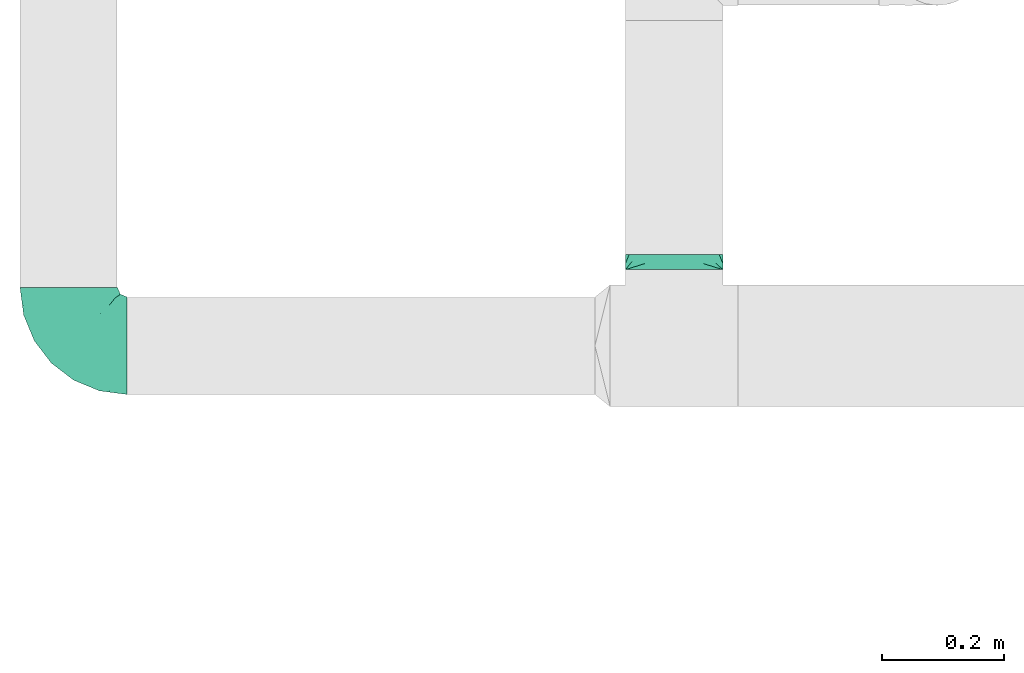
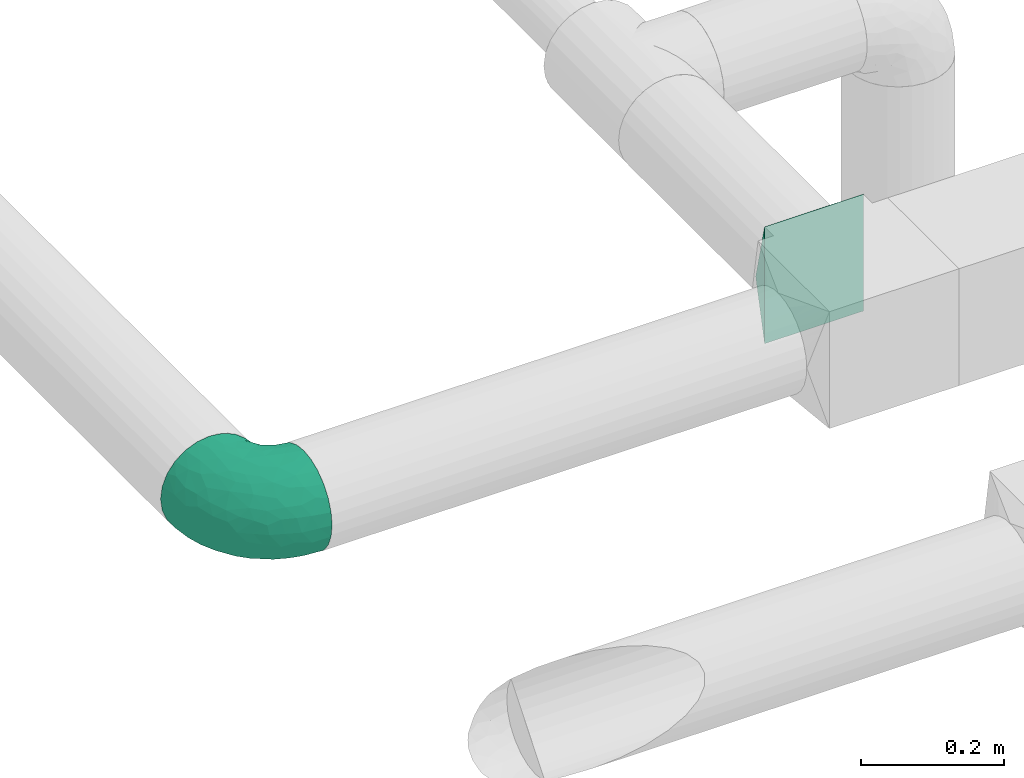
# One storey, part 7 of 12: 2 flow fittings.
"""IFC2X3 building model written with IfcOpenShell, lengths in millimetres."""

from ifc_helpers import new_model, entity, si_unit, converted_unit, derived_unit, direction, frame, origin, place, context, subcontext, project, spatial, faceted_brep, source, transform, mapped, material, type_object, type_shapes, element, save


model = new_model("IFC2X3")

# Units and contexts
model_context = context("Model", 3, precision=0.01, world=origin(), true_north=direction((6.12303176911189e-17, 1.0)))
body_context = subcontext(model_context, "Body", "Model", "MODEL_VIEW")
ifc_project = project(units=[si_unit("LENGTHUNIT", "METRE", prefix="MILLI"), si_unit("AREAUNIT", "SQUARE_METRE"), si_unit("VOLUMEUNIT", "CUBIC_METRE"), converted_unit("PLANEANGLEUNIT", "DEGREE", entity("IfcRatioMeasure", 0.0174532925199433), si_unit("PLANEANGLEUNIT", "RADIAN"), dimensions=[0, 0, 0, 0, 0, 0, 0]), si_unit("MASSUNIT", "GRAM", prefix="KILO"), derived_unit("MASSDENSITYUNIT", [(si_unit("MASSUNIT", "GRAM", prefix="KILO"), 1), (si_unit("LENGTHUNIT", "METRE"), -3)]), si_unit("TIMEUNIT", "SECOND"), si_unit("FREQUENCYUNIT", "HERTZ"), si_unit("THERMODYNAMICTEMPERATUREUNIT", "DEGREE_CELSIUS"), derived_unit("THERMALTRANSMITTANCEUNIT", [(si_unit("MASSUNIT", "GRAM", prefix="KILO"), 1), (si_unit("THERMODYNAMICTEMPERATUREUNIT", "KELVIN"), -1), (si_unit("TIMEUNIT", "SECOND"), -3)]), derived_unit("VOLUMETRICFLOWRATEUNIT", [(si_unit("LENGTHUNIT", "METRE"), 3), (si_unit("TIMEUNIT", "SECOND"), -1)]), si_unit("ELECTRICCURRENTUNIT", "AMPERE"), si_unit("ELECTRICVOLTAGEUNIT", "VOLT"), si_unit("POWERUNIT", "WATT"), si_unit("FORCEUNIT", "NEWTON", prefix="KILO"), si_unit("ILLUMINANCEUNIT", "LUX"), si_unit("LUMINOUSFLUXUNIT", "LUMEN"), si_unit("LUMINOUSINTENSITYUNIT", "CANDELA"), derived_unit("USERDEFINED", [(si_unit("MASSUNIT", "GRAM", prefix="KILO"), -1), (si_unit("LENGTHUNIT", "METRE"), -2), (si_unit("TIMEUNIT", "SECOND"), 3), (si_unit("LUMINOUSFLUXUNIT", "LUMEN"), 1)]), derived_unit("LINEARVELOCITYUNIT", [(si_unit("LENGTHUNIT", "METRE"), 1), (si_unit("TIMEUNIT", "SECOND"), -1)]), si_unit("PRESSUREUNIT", "PASCAL"), derived_unit("USERDEFINED", [(si_unit("LENGTHUNIT", "METRE"), -2), (si_unit("MASSUNIT", "GRAM", prefix="KILO"), 1), (si_unit("TIMEUNIT", "SECOND"), -2)])], contexts=[model_context])

# Site, building, storey
site_placement = place(None, origin())
site = spatial("IfcSite", under=ifc_project, at=site_placement, CompositionType="ELEMENT")
building_placement = place(site_placement, origin())
building = spatial("IfcBuilding", under=site, at=building_placement, CompositionType="ELEMENT")
storey_placement = place(building_placement, frame((0.0, 0.0, 4000.0)))
storey = spatial("IfcBuildingStorey", under=building, at=storey_placement, Name="01 Level", CompositionType="ELEMENT", Elevation=4000.0)

# Flow fittings
duct_fitting_type_1 = type_object("IfcDuctFittingType", Name="Air_Elbow short_Circ", PredefinedType="NOTDEFINED")
shared_shape_1 = source(origin(), body_context, "Body", "Brep", [
    faceted_brep([(-96.0, 0.0, -80.0), (-96.0, -20.7055236082018, -77.2740661031254), (-96.0, -40.0, -69.2820323027551), (-96.0, -56.5685424949239, -56.5685424949238), (-96.0, -69.2820323027551, -40.0), (-96.0, -77.2740661031255, -20.7055236082016), (-96.0, -80.0, 0.0), (-96.0, -77.2740661031253, 20.7055236082021), (-96.0, -69.2820323027549, 40.0), (-96.0, -56.5685424949235, 56.5685424949241), (-96.0, -40.0, 69.2820323027553), (-96.0, -30.3527618041005, 73.2780492029404), (-96.0, -20.7055236082013, 77.2740661031256), (-96.0, 0.0, 80.0), (-96.0, 20.705523608202, 77.2740661031254), (-96.0, 40.0, 69.2820323027549), (-96.0, 56.568542494924, 56.5685424949236), (-96.0, 69.2820323027553, 40.0), (-96.0, 77.2740661031256, 20.7055236082014), (-96.0, 80.0, 0.0), (-96.0, 77.2740661031254, -20.7055236082019), (-96.0, 69.282032302755, -40.0), (-96.0, 56.5685424949237, -56.5685424949239), (-96.0, 40.0, -69.2820323027552), (-96.0, 20.7055236082015, -77.2740661031255), (0.0, -96.0, -80.0), (20.7055236082025, -96.0, -77.2740661031255), (40.0, -96.0, -69.2820323027552), (56.5685424949246, -96.0, -56.5685424949239), (69.2820323027559, -96.0, -40.0), (77.2740661031264, -96.0, -20.7055236082019), (80.0, -96.0, 0.0), (77.2740661031265, -96.0, 20.7055236082014), (69.2820323027562, -96.0, 40.0), (56.5685424949249, -96.0, 56.5685424949236), (40.0, -96.0, 69.2820323027549), (20.7055236082029, -96.0, 77.2740661031254), (0.0, -96.0, 80.0), (-20.7055236082004, -96.0, 77.2740661031256), (-40.0, -96.0, 69.2820323027553), (-56.5685424949226, -96.0, 56.5685424949241), (-69.2820323027539, -96.0, 40.0), (-77.2740661031244, -96.0, 20.7055236082021), (-80.0, -96.0, 0.0), (-77.2740661031245, -96.0, -20.7055236082016), (-69.2820323027542, -96.0, -40.0), (-56.5685424949229, -96.0, -56.5685424949238), (-40.0, -96.0, -69.2820323027551), (-30.3527618041, -96.0, -73.2780492029402), (-20.7055236082008, -96.0, -77.2740661031254), (-69.6571465232348, -6.28172173912476, 79.9611058756859), (-66.7862289407348, 74.1387210661139, 22.9795507758541), (-78.4902527850466, 65.2482264041437, 44.9229732355936), (-55.1380888291464, 64.4450584799279, 39.5029426177976), (-75.1250134759213, -46.3506195730757, 68.0011973810265), (-79.9123689128389, -22.4151301859584, 77.2816866630488), (-67.1316735243184, 51.7530432423058, 58.5204707533666), (-62.9760666105318, 34.5362195419601, 70.0448030595901), (-46.2820694578435, 43.7397705581167, 60.5188244193914), (-76.2276812833835, 77.3969248578635, 0.0), (-50.4478480619551, 74.0029454268759, 0.0), (-6.30632028234235, -70.6421404093778, 79.9513108199466), (-27.189372084162, -68.980536479128, 76.8941402015288), (-29.8609237116382, 28.9682345099716, 65.8760199345924), (-47.7584488981354, 13.6212410427434, 76.3881123659885), (43.7397637815864, -46.2820598522933, 60.518827155348), (51.7530435574228, -67.1316742002235, 58.5204705859065), (57.6005967886466, -33.4719572927763, 39.0176496769077), (-74.2591571701267, 14.3645886695287, 78.2829835259588), (7.8513563843086, 42.4938374080907, 21.3232874317503), (23.3846344985257, 27.9066135199674, 24.7887114209846), (28.4507934888335, 28.4507934888321, 0.0), (-84.190871651952, -70.905997349447, 41.7100461919055), (10.21505333872, 32.0754161621096, 38.020212353501), (-0.0180155578363953, 25.9284255475521, 53.836744023285), (24.7272484782103, 2.06889411058577, 53.4325037134459), (-41.7574890626937, -15.123136403511, 79.988056483004), (-64.5619855594544, -27.52018553659, 77.2892967298799), (-8.0, 56.420471066061, 0.0), (-29.2239240309769, 65.2117082464685, 0.0), (-24.5336756868846, 60.9669573051438, 23.5003835585885), (-16.4008295437786, -51.3122057461681, 79.8609584412684), (-84.6862915010143, -84.6862915010152, 0.0), (-83.0529092063249, -83.0529092103045, 19.0855009657076), (-82.4185651555764, -62.2587017800419, 53.3339952483838), (-46.3022193149449, -75.902750025661, 67.8445262622594), (-9.5260688639158, 47.7232209131232, 35.4187162694583), (74.1387213421635, -66.7862279048973, 22.9795492840646), (34.536215572589, -62.976064096567, 70.0448048426748), (14.3645870599314, -74.259154996167, 78.2829837700474), (65.2482273833467, -78.4902510979302, 44.9229715327465), (-25.6317751341749, -1.2640655514879, 76.9124052095498), (-12.3935655196116, -25.4017250572252, 78.8652642576962), (60.9669574479924, -24.5336725945725, 23.5003789659965), (64.4450597015273, -55.1380839274934, 39.5029384026545), (69.8186739706361, -42.5625104806759, 16.7980672722629), (77.3969247188647, -76.2276802275763, 0.0), (74.002945426877, -50.4478480619565, 0.0), (-52.4774893100348, -53.0631556360015, 72.0041598972686), (-66.5995156060253, -66.5995146556305, 58.6370817132137), (-76.4857465466113, -78.9385356944492, 38.5867538667356), (-62.2587016209511, -82.4185645906685, 53.3339956492136), (13.6212369177471, -47.7584433090926, 76.3881128402526), (28.9682276847195, -29.8609133580269, 65.8760207540895), (-6.49930484510329, 53.7890406240985, 15.4645725223014), (-33.731289034344, -40.0214486160993, 79.0537019298314), (46.1336936566893, -26.2441492635858, 50.151541479116), (50.0005984633279, -1.26038287501495, 17.5763945268078), (56.4204710660622, -8.0, 0.0), (42.4356322774479, 10.225396744416, 0.0), (-45.4536887619888, 68.8356359385787, 23.6914879663761), (-33.3493864711472, 57.4572215948989, 39.1720709545353), (35.9683398342664, 11.0724559744972, 30.5391080332169), (-26.2441652621668, 46.1336984778153, 50.1515448602929), (36.6749123583047, 17.5982116941791, 14.5644188861001), (65.2117082464696, -29.2239240309784, 0.0), (49.5968730216335, -12.1440064858134, 34.8325942562253), (-47.1533280807863, -29.0746114834461, 78.9127210009486), (-0.981722938535007, -51.3162880079176, 79.4920802366619), (-1.95170750213435, -1.95169859379814, 70.9272590604952), (12.4951682569875, -20.0804783439543, 71.2292489374933), (13.0725391330592, -1.13338064801589, 63.5790506070627), (-1.93327092594732, 13.4823821925323, 63.7412032706882), (-18.9298205951927, 13.0048872663631, 70.6672094580024), (10.2253967444173, 42.4356322774466, 0.0), (-68.9805369123341, -27.1893702897943, -76.8941406355589), (-46.3506180288022, -75.1250185023919, -68.0011970559212), (-27.5201921618733, -64.5619784506715, -77.2892959136582), (-22.4151342180024, -79.9123577737124, -77.2816862456941), (-74.2591561090454, 14.364589592643, -78.2829832920378), (-66.78622820047, 74.1387209331735, -22.9795507950237), (-42.5625109127564, 69.8186736490614, -16.7980693145318), (-70.6421421271429, -6.30631801763141, -79.9513108797024), (-1.2640784754681, -25.6317655571971, -76.9124065444174), (-15.1231475192353, -41.7574898106582, -79.9880566497423), (-25.401718902627, -12.3935649209934, -78.8652635038296), (-82.4185656924104, -62.258701559575, -53.3339952529289), (-66.5995166501766, -66.5995137008527, -58.6370816545605), (-78.9385361639639, -76.4857467527193, -38.5867530236755), (53.7890400497189, -6.49930371043273, -15.4645720709197), (60.9669567069012, -24.5336743104721, -23.5003834743896), (-24.5336751436549, 60.9669572920351, -23.5003828649414), (-55.1380878256228, 64.4450583029017, -39.5029424837467), (-46.2820677406335, 43.7397707662098, -60.5188237522514), (-26.2441631797834, 46.1336980827234, -50.1515441608816), (-29.8609212227281, 28.9682353164184, -65.8760186412515), (74.1387206827049, -66.7862275406284, -22.9795512458422), (-40.0214489824224, -33.7312845774564, -79.0537024061946), (-78.4902524468744, 65.2482264004152, -44.9229731872606), (-75.902751427461, -46.3022186029078, -67.8445263463497), (-70.9059970555813, -84.1908706304995, -41.7100473389448), (-62.9760652707231, 34.536220162299, -70.044802546446), (-67.1316724627346, 51.7530434014037, -58.5204704180807), (-33.4719630839568, 57.6005950429912, -39.0176564793206), (-51.3122062597491, -16.4008248291117, -79.8609586691244), (-6.28171714934502, -69.65712797409, -79.9611061760713), (51.7530427306645, -67.1316703492073, -58.5204706539109), (-83.0529092397056, -83.0529091932979, -19.0855009185769), (68.8356349913375, -45.45368838847, -23.6914905340598), (-62.258701383479, -82.4185638376438, -53.3339962098694), (34.53621889603, -62.9760621802168, -70.0448028055675), (-1.26038544288408, 50.0005998980998, -17.5763953891677), (14.3645887716112, -74.2591526334116, -78.2829833202131), (13.6212385978137, -47.75844096294, -76.3881120677864), (65.2482261461557, -78.4902526871683, -44.9229735979605), (32.0754071702863, 10.2150656939878, -38.0202105656364), (25.9284207554091, -0.0180077987247146, -53.8367428868672), (2.068884460932, 24.7272580800759, -53.4325021883878), (47.723215348146, -9.52606271707191, -35.4187195087105), (42.4938359077841, 7.8513587520169, -21.3232866357369), (27.9066094773716, 23.3846413342612, -24.7887058003424), (28.9682309044935, -29.8609168472814, -65.8760199178674), (64.4450577206072, -55.1380878066959, -39.5029434692504), (-53.063150048133, -52.4774843719861, -72.0041634993662), (43.7397687897612, -46.2820667462245, -60.5188250739327), (-47.7584463040963, 13.6212426330217, -76.3881115880261), (57.4572201066452, -33.3493827160302, -39.1720708806551), (11.0724494499294, 35.9683446288498, -30.5391089716619), (46.1336964749623, -26.2441642243134, -50.1515465265606), (17.5982028158329, 36.6749194460897, -14.5644209948051), (-12.1440097531109, 49.5968729214507, -34.8325978072281), (-29.0746218055845, -47.1533256390974, -78.912719851915), (-51.3162911259858, -0.981717610547608, -79.4920798409907), (-1.95170139871169, -1.95169735730944, -70.9272563527003), (-20.0804667507281, 12.4951842966219, -71.2292388196267), (-1.13337124471279, 13.072540998247, -63.5790448193562), (13.4823844636247, -1.93327501577089, -63.7412039856557), (13.0048800657406, -18.9298191902065, -70.6672121474654)], [[[0, 1, 2, 3, 4, 5, 6, 7, 8, 9, 10, 11, 12, 13, 14, 15, 16, 17, 18, 19, 20, 21, 22, 23, 24]], [[25, 26, 27, 28, 29, 30, 31, 32, 33, 34, 35, 36, 37, 38, 39, 40, 41, 42, 43, 44, 45, 46, 47, 48, 49]], [[50, 13, 12]], [[51, 52, 53]], [[10, 54, 55]], [[56, 57, 58]], [[59, 51, 60]], [[61, 62, 38]], [[63, 57, 64]], [[65, 66, 67]], [[17, 16, 52]], [[15, 57, 56]], [[14, 13, 68]], [[69, 70, 71]], [[8, 7, 72]], [[68, 64, 57]], [[73, 74, 75]], [[76, 50, 77]], [[57, 15, 14]], [[9, 54, 10]], [[55, 12, 11, 10]], [[78, 79, 80]], [[62, 61, 81]], [[82, 83, 6]], [[63, 58, 57]], [[83, 7, 6]], [[8, 72, 84]], [[56, 16, 15]], [[84, 9, 8]], [[62, 85, 39]], [[86, 74, 73]], [[59, 18, 51]], [[18, 17, 51]], [[32, 87, 33]], [[35, 34, 66]], [[36, 88, 89]], [[90, 34, 33]], [[88, 36, 35]], [[91, 76, 92]], [[90, 33, 87]], [[93, 94, 95]], [[35, 66, 88]], [[32, 96, 87]], [[85, 40, 39]], [[87, 97, 95]], [[98, 99, 85]], [[41, 100, 42]], [[42, 100, 83]], [[101, 99, 100]], [[102, 88, 103]], [[43, 83, 82]], [[104, 78, 80]], [[38, 62, 39]], [[98, 85, 62]], [[92, 76, 105]], [[65, 106, 103]], [[101, 41, 40]], [[37, 61, 38]], [[107, 108, 109]], [[51, 53, 110]], [[37, 36, 89]], [[79, 110, 80]], [[110, 79, 60]], [[111, 110, 53]], [[112, 70, 73]], [[113, 86, 111]], [[71, 114, 109]], [[75, 103, 106]], [[93, 95, 115]], [[37, 89, 61]], [[108, 93, 115]], [[67, 93, 116]], [[107, 116, 93]], [[13, 50, 68]], [[117, 76, 77]], [[98, 117, 77]], [[99, 54, 84]], [[40, 85, 101]], [[98, 54, 99]], [[105, 62, 81]], [[89, 118, 61]], [[88, 66, 65]], [[94, 66, 90]], [[16, 56, 52]], [[111, 53, 56]], [[76, 64, 50]], [[64, 76, 91]], [[119, 92, 120]], [[61, 118, 81]], [[120, 121, 119]], [[116, 112, 75]], [[121, 122, 119]], [[119, 122, 123]], [[113, 63, 74]], [[119, 123, 91]], [[86, 113, 74]], [[122, 121, 75]], [[54, 98, 77]], [[105, 98, 62]], [[59, 19, 18]], [[97, 87, 96]], [[32, 31, 96]], [[102, 89, 88]], [[14, 68, 57]], [[64, 68, 50]], [[41, 101, 100]], [[99, 101, 85]], [[9, 84, 54]], [[100, 99, 72]], [[81, 92, 105]], [[102, 92, 118]], [[81, 118, 92]], [[102, 118, 89]], [[84, 72, 99]], [[83, 100, 72]], [[72, 7, 83]], [[42, 83, 43]], [[17, 52, 51]], [[53, 52, 56]], [[34, 90, 66]], [[94, 90, 87]], [[55, 54, 77]], [[55, 50, 12]], [[55, 77, 50]], [[60, 51, 110]], [[80, 110, 111]], [[86, 104, 80]], [[58, 113, 111]], [[111, 86, 80]], [[73, 69, 86]], [[69, 73, 70]], [[112, 73, 75]], [[69, 124, 104]], [[108, 107, 93]], [[112, 114, 70]], [[93, 67, 94]], [[112, 107, 114]], [[70, 114, 71]], [[109, 114, 107]], [[106, 116, 75]], [[116, 107, 112]], [[94, 67, 66]], [[67, 116, 106]], [[115, 95, 97]], [[69, 104, 86]], [[78, 104, 124]], [[69, 71, 124]], [[87, 95, 94]], [[88, 65, 103]], [[106, 65, 67]], [[56, 58, 111]], [[113, 58, 63]], [[117, 105, 76]], [[105, 117, 98]], [[63, 64, 123]], [[119, 91, 92]], [[91, 123, 64]], [[74, 63, 122]], [[123, 122, 63]], [[74, 122, 75]], [[121, 103, 75]], [[103, 121, 120]], [[120, 102, 103]], [[102, 120, 92]], [[1, 125, 2]], [[126, 127, 128]], [[129, 0, 24]], [[130, 60, 131]], [[0, 132, 1]], [[133, 134, 135]], [[136, 137, 138]], [[139, 108, 140]], [[3, 136, 4]], [[141, 142, 131]], [[138, 5, 4]], [[143, 144, 145]], [[30, 29, 146]], [[135, 134, 147]], [[148, 21, 130]], [[149, 3, 2]], [[20, 59, 130]], [[45, 44, 150]], [[151, 23, 152]], [[143, 152, 153]], [[152, 23, 22]], [[151, 24, 23]], [[125, 132, 154]], [[21, 148, 22]], [[155, 25, 49]], [[151, 129, 24]], [[20, 130, 21]], [[156, 28, 27]], [[157, 82, 6]], [[115, 158, 140]], [[157, 44, 43]], [[5, 138, 157]], [[150, 159, 45]], [[160, 27, 26]], [[161, 78, 124]], [[45, 159, 46]], [[128, 49, 48, 47]], [[2, 125, 149]], [[134, 155, 127]], [[162, 163, 160]], [[29, 28, 164]], [[126, 47, 46]], [[165, 166, 167]], [[25, 162, 26]], [[166, 165, 168]], [[132, 125, 1]], [[108, 115, 140]], [[169, 170, 71]], [[171, 160, 163]], [[27, 160, 156]], [[146, 164, 172]], [[173, 137, 149]], [[97, 96, 146]], [[171, 174, 160]], [[175, 151, 145]], [[160, 174, 156]], [[173, 149, 125]], [[47, 126, 128]], [[158, 115, 97]], [[6, 5, 157]], [[146, 172, 158]], [[96, 30, 146]], [[176, 158, 172]], [[177, 170, 165]], [[178, 168, 176]], [[71, 179, 124]], [[167, 145, 144]], [[141, 131, 79]], [[96, 31, 30]], [[78, 141, 79]], [[153, 141, 180]], [[161, 180, 141]], [[25, 155, 162]], [[147, 134, 181]], [[173, 181, 127]], [[137, 126, 159]], [[3, 149, 136]], [[173, 126, 137]], [[147, 125, 154]], [[129, 182, 132]], [[151, 152, 143]], [[142, 152, 148]], [[28, 156, 164]], [[176, 172, 156]], [[134, 163, 155]], [[163, 134, 133]], [[183, 135, 184]], [[132, 182, 154]], [[184, 185, 183]], [[180, 177, 167]], [[185, 186, 183]], [[183, 186, 187]], [[178, 171, 166]], [[183, 187, 133]], [[168, 178, 166]], [[186, 185, 167]], [[126, 173, 127]], [[147, 173, 125]], [[60, 130, 59]], [[20, 19, 59]], [[0, 129, 132]], [[175, 129, 151]], [[26, 162, 160]], [[163, 162, 155]], [[4, 136, 138]], [[137, 136, 149]], [[46, 159, 126]], [[138, 137, 150]], [[154, 135, 147]], [[175, 135, 182]], [[154, 182, 135]], [[175, 182, 129]], [[159, 150, 137]], [[157, 138, 150]], [[82, 157, 43]], [[150, 44, 157]], [[29, 164, 146]], [[172, 164, 156]], [[22, 148, 152]], [[142, 148, 130]], [[155, 128, 127]], [[128, 155, 49]], [[97, 146, 158]], [[140, 158, 176]], [[168, 139, 140]], [[174, 178, 176]], [[176, 168, 140]], [[165, 169, 168]], [[169, 165, 170]], [[177, 165, 167]], [[169, 109, 139]], [[78, 161, 141]], [[177, 179, 170]], [[141, 153, 142]], [[177, 161, 179]], [[170, 179, 71]], [[124, 179, 161]], [[144, 180, 167]], [[180, 161, 177]], [[142, 153, 152]], [[153, 180, 144]], [[79, 131, 60]], [[169, 139, 168]], [[108, 139, 109]], [[169, 71, 109]], [[130, 131, 142]], [[151, 143, 145]], [[144, 143, 153]], [[156, 174, 176]], [[178, 174, 171]], [[147, 181, 173]], [[181, 134, 127]], [[171, 163, 187]], [[183, 133, 135]], [[133, 187, 163]], [[166, 171, 186]], [[187, 186, 171]], [[166, 186, 167]], [[185, 145, 167]], [[145, 185, 184]], [[184, 175, 145]], [[175, 184, 135]]]),
])
type_shapes(duct_fitting_type_1, [shared_shape_1])
flow_fitting_1_placement = place(storey_placement, frame((22191.748982204, -68506.4439409626, 3000.0), z_axis=(0.0, 0.0, 1.0), x_axis=(-1.0, 0.0, 0.0)))
element("IfcFlowFitting", 1, at=flow_fitting_1_placement, inside=storey, type_object=duct_fitting_type_1, Name="elbow_short_001:Air_Elbow short_Circ", ObjectType="elbow_short_001:Air_Elbow short_Circ", context=body_context, shape_type="MappedRepresentation", body=[
    mapped(shared_shape_1, transform((0.0, 0.0, 0.0), scale=1.0)),
])
ifc_material = material(Name="Material_Duct")
duct_fitting_type_2 = type_object("IfcDuctFittingType", Name="Air_Multi shape transition_Circ", PredefinedType="NOTDEFINED", material=ifc_material)
shared_shape_2 = source(origin(), body_context, "Body", "Brep", [
    faceted_brep([(25.0, 0.0, -80.0), (25.0, 7.55917892584856, -78.4963858244121), (25.0, 15.1183578516973, -76.9927716488251), (25.0, 22.8665162204521, -75.4515671248636), (25.0, 26.7405954048296, -74.6809648628828), (25.0, 30.614674589207, -73.9103626009021), (25.0, 37.1031415656362, -69.5749075744073), (25.0, 43.5916085420653, -65.2394525479126), (25.0, 50.0800755184945, -60.9039975214178), (25.0, 56.5685424949236, -56.5685424949231), (25.0, 60.9039975214184, -50.0800755184939), (25.0, 65.2394525479132, -43.5916085420648), (25.0, 69.574907574408, -37.1031415656356), (25.0, 73.9103626009028, -30.6146745892065), (25.0, 75.4515671268645, -22.8665162103963), (25.0, 76.9927716528262, -15.1183578315862), (25.0, 77.7445787396197, -11.3387683736895), (25.0, 78.4963858264131, -7.55917891579276), (25.0, 80.0, 0.0), (25.0, 78.496385824413, 7.55917892584876), (25.0, 76.992771648826, 15.1183578516975), (25.0, 75.4515671248645, 22.8665162204524), (25.0, 74.6809648628837, 26.7405954048298), (25.0, 73.9103626009029, 30.6146745892072), (25.0, 69.5749075744081, 37.1031415656364), (25.0, 65.2394525479133, 43.5916085420656), (25.0, 60.9039975214185, 50.0800755184947), (25.0, 56.5685424949237, 56.5685424949239), (25.0, 50.0800755184946, 60.9039975214187), (25.0, 43.5916085420654, 65.2394525479134), (25.0, 37.1031415656362, 69.5749075744082), (25.0, 30.6146745892071, 73.910362600903), (25.0, 22.8665162103969, 75.4515671268647), (25.0, 15.1183578315867, 76.9927716528263), (25.0, 11.33876837369, 77.7445787396197), (25.0, 7.55917891579327, 78.4963858264132), (25.0, 0.0, 80.0), (25.0, -7.55917892584888, 78.496385824413), (25.0, -15.1183578516976, 76.992771648826), (25.0, -22.8665162204525, 75.4515671248644), (25.0, -26.7405954048299, 74.6809648628836), (25.0, -30.6146745892073, 73.9103626009029), (25.0, -37.1031415656365, 69.5749075744081), (25.0, -43.5916085420656, 65.2394525479133), (25.0, -50.0800755184948, 60.9039975214185), (25.0, -56.5685424949239, 56.5685424949237), (25.0, -60.9039975214187, 50.0800755184945), (25.0, -65.2394525479135, 43.5916085420653), (25.0, -69.5749075744082, 37.1031415656362), (25.0, -73.910362600903, 30.614674589207), (25.0, -75.4515671268647, 22.8665162103968), (25.0, -76.9927716528263, 15.1183578315866), (25.0, -77.7445787396197, 11.3387683736899), (25.0, -78.4963858264131, 7.55917891579322), (25.0, -80.0, 0.0), (25.0, -78.496385824413, -7.55917892584782), (25.0, -76.992771648826, -15.1183578516966), (25.0, -75.4515671248645, -22.8665162204514), (25.0, -74.6809648628837, -26.7405954048289), (25.0, -73.910362600903, -30.6146745892063), (25.0, -69.5749075744082, -37.1031415656355), (25.0, -65.2394525479134, -43.5916085420646), (25.0, -60.9039975214186, -50.0800755184938), (25.0, -56.5685424949238, -56.5685424949229), (25.0, -50.0800755184946, -60.9039975214177), (25.0, -43.5916085420654, -65.2394525479125), (25.0, -37.1031415656363, -69.5749075744073), (25.0, -30.6146745892071, -73.9103626009021), (25.0, -22.8665162103969, -75.4515671268637), (25.0, -15.1183578315867, -76.9927716528254), (25.0, -11.33876837369, -77.7445787396188), (25.0, -7.55917891579331, -78.4963858264122), (0.0, -80.0, -100.0), (0.0, -80.0, 100.0), (0.0, 80.0, 100.0), (0.0, 80.0, -100.0), (9.76070875417778, 48.7657319866316, 92.1914329966588), (6.50713916945185, 59.1771546577547, 94.7942886644397), (3.25356948584772, 80.0, 86.9857220566105), (12.5000000004112, 69.9443399352347, 76.5204921859004), (22.0035694858477, 80.0, 11.9857220566093), (19.0071389716954, 80.0, 23.9714441132186), (16.0107084575432, 80.0, 35.957166169828), (13.0142779433909, 80.0, 47.9428882264372), (9.76070845754316, 80.0, 60.9571661698283), (13.0142783389037, 38.3543093155085, 89.5885773288778), (16.0107087541778, 28.7657319866313, 87.1914329966584), (19.0071391694519, 19.1771546577542, 84.7942886644389), (20.5053543770889, 14.3828659933156, 83.5957164983292), (22.0035695847259, 9.58857732887701, 82.3971443322195), (6.50713897169544, 80.0, 73.9714441132194), (3.25356958472593, 69.5885773288778, 97.3971443322206), (22.0035695847259, 80.0, -11.9857216610957), (20.5053543770889, 80.0, -17.9785824916439), (19.0071391694518, 80.0, -23.9714433221921), (16.0107087541778, 80.0, -35.9571649832885), (13.0142783389037, 80.0, -47.9428866443849), (9.76070875417777, 80.0, -60.9571649832887), (6.50713916945184, 80.0, -73.9714433221924), (3.25356958472592, 80.0, -86.9857216610962), (3.25356948584772, 69.5885776452881, -97.3971444113217), (12.5000000004112, 66.5204921862289, -79.9443399349049), (22.0035694858477, 9.58857764528726, -82.397144411321), (19.0071389716954, 19.1771552905747, -84.794288822643), (16.0107084575432, 28.7657329358621, -87.1914332339649), (13.0142779433909, 38.3543105811496, -89.5885776452868), (9.76070845754315, 48.7657329358624, -92.1914332339651), (6.50713897169543, 59.1771552905753, -94.7942888226434), (22.0035695847259, -9.58857732887686, -82.3971443322185), (20.5053543770889, -14.3828659933154, -83.5957164983281), (19.0071391694519, -19.1771546577538, -84.7942886644378), (16.0107087541778, -28.7657319866308, -87.1914329966572), (13.0142783389037, -38.3543093155078, -89.5885773288766), (9.76070875417778, -48.7657319866307, -92.1914329966574), (6.50713916945185, -59.1771546577536, -94.7942886644383), (3.25356958472593, -69.5885773288765, -97.3971443322191), (3.25356948584772, -80.0, -86.985722056609), (12.5000000004112, -69.9443399352339, -76.5204921858991), (22.0035694858477, -80.0, -11.9857220566083), (19.0071389716954, -80.0, -23.9714441132175), (16.0107084575432, -80.0, -35.9571661698268), (13.0142779433909, -80.0, -47.942888226436), (9.76070845754316, -80.0, -60.957166169827), (6.50713897169544, -80.0, -73.971444113218), (22.0035695847259, -80.0, 11.9857216610963), (20.5053543770889, -80.0, 17.9785824916446), (19.0071391694519, -80.0, 23.9714433221928), (16.0107087541778, -80.0, 35.9571649832894), (13.0142783389037, -80.0, 47.9428866443859), (9.76070875417777, -80.0, 60.9571649832898), (6.50713916945185, -80.0, 73.9714433221937), (3.25356958472593, -80.0, 86.9857216610977), (3.25356948584772, -69.5885776452868, 97.3971444113232), (12.5000000004112, -66.5204921862283, 79.9443399349061), (22.0035694858477, -9.58857764528735, 82.397144411322), (19.0071389716954, -19.1771552905746, 84.794288822644), (16.0107084575432, -28.7657329358618, 87.1914332339661), (13.0142779433909, -38.354310581149, 89.5885776452881), (9.76070845754316, -48.7657329358616, 92.1914332339665), (6.50713897169544, -59.1771552905742, 94.7942888226448)], [[[0, 1, 2, 3, 4, 5, 6, 7, 8, 9, 10, 11, 12, 13, 14, 15, 16, 17, 18, 19, 20, 21, 22, 23, 24, 25, 26, 27, 28, 29, 30, 31, 32, 33, 34, 35, 36, 37, 38, 39, 40, 41, 42, 43, 44, 45, 46, 47, 48, 49, 50, 51, 52, 53, 54, 55, 56, 57, 58, 59, 60, 61, 62, 63, 64, 65, 66, 67, 68, 69, 70, 71]], [[72, 73, 74, 75]], [[76, 29, 77]], [[76, 31, 30, 29]], [[78, 74, 79]], [[27, 79, 28]], [[20, 19, 18, 80, 81, 82, 83, 84, 23, 22, 21]], [[31, 76, 85, 86, 87, 88, 89, 36, 35, 34, 33, 32]], [[27, 26, 79]], [[90, 25, 84]], [[79, 74, 91]], [[84, 25, 24, 23]], [[26, 25, 90]], [[78, 79, 26]], [[78, 26, 90]], [[29, 28, 77]], [[91, 77, 28]], [[91, 28, 79]], [[75, 74, 78, 90, 84, 83, 82, 81, 80, 18, 92, 93, 94, 95, 96, 97, 98, 99]], [[97, 11, 98]], [[97, 13, 12, 11]], [[100, 75, 101]], [[9, 101, 10]], [[2, 1, 0, 102, 103, 104, 105, 106, 5, 4, 3]], [[13, 97, 96, 95, 94, 93, 92, 18, 17, 16, 15, 14]], [[9, 8, 101]], [[107, 7, 106]], [[101, 75, 99]], [[106, 7, 6, 5]], [[8, 7, 107]], [[100, 101, 8]], [[100, 8, 107]], [[11, 10, 98]], [[99, 98, 10]], [[99, 10, 101]], [[72, 75, 100, 107, 106, 105, 104, 103, 102, 0, 108, 109, 110, 111, 112, 113, 114, 115]], [[113, 65, 114]], [[113, 67, 66, 65]], [[116, 72, 117]], [[63, 117, 64]], [[56, 55, 54, 118, 119, 120, 121, 122, 59, 58, 57]], [[67, 113, 112, 111, 110, 109, 108, 0, 71, 70, 69, 68]], [[63, 62, 117]], [[123, 61, 122]], [[117, 72, 115]], [[122, 61, 60, 59]], [[62, 61, 123]], [[116, 117, 62]], [[116, 62, 123]], [[65, 64, 114]], [[115, 114, 64]], [[115, 64, 117]], [[124, 125, 126, 127, 128, 129, 130, 131, 73, 72, 116, 123, 122, 121, 120, 119, 118, 54]], [[129, 47, 130]], [[129, 49, 48, 47]], [[132, 73, 133]], [[45, 133, 46]], [[38, 37, 36, 134, 135, 136, 137, 138, 41, 40, 39]], [[49, 129, 128, 127, 126, 125, 124, 54, 53, 52, 51, 50]], [[45, 44, 133]], [[139, 43, 138]], [[133, 73, 131]], [[138, 43, 42, 41]], [[44, 43, 139]], [[132, 133, 44]], [[132, 44, 139]], [[47, 46, 130]], [[131, 130, 46]], [[131, 46, 133]], [[89, 88, 87, 86, 85, 76, 77, 91, 74, 73, 132, 139, 138, 137, 136, 135, 134, 36]]]),
])
type_shapes(duct_fitting_type_2, [shared_shape_2])
flow_fitting_2_placement = place(storey_placement, frame((23185.9900708518, -68381.4439409626, 3000.0), z_axis=(0.0, 0.0, 1.0), x_axis=(0.0, 1.0, 0.0)))
element("IfcFlowFitting", 2, at=flow_fitting_2_placement, inside=storey, type_object=duct_fitting_type_2, material=ifc_material, Name="multi_shape_trans_001:Air_Multi shape transition_Circ", ObjectType="multi_shape_trans_001:Air_Multi shape transition_Circ", context=body_context, shape_type="MappedRepresentation", body=[
    mapped(shared_shape_2, transform((0.0, 0.0, 0.0), scale=1.0)),
])

save(model, "model.ifc")
